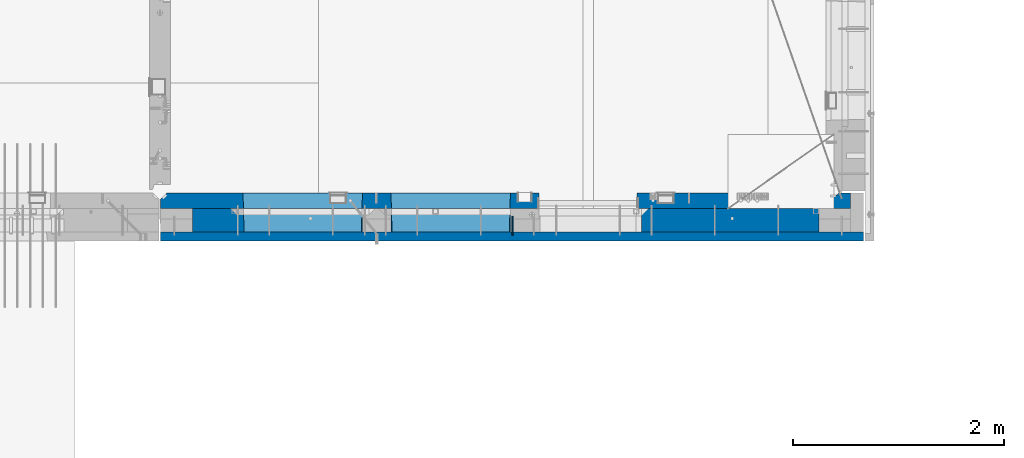
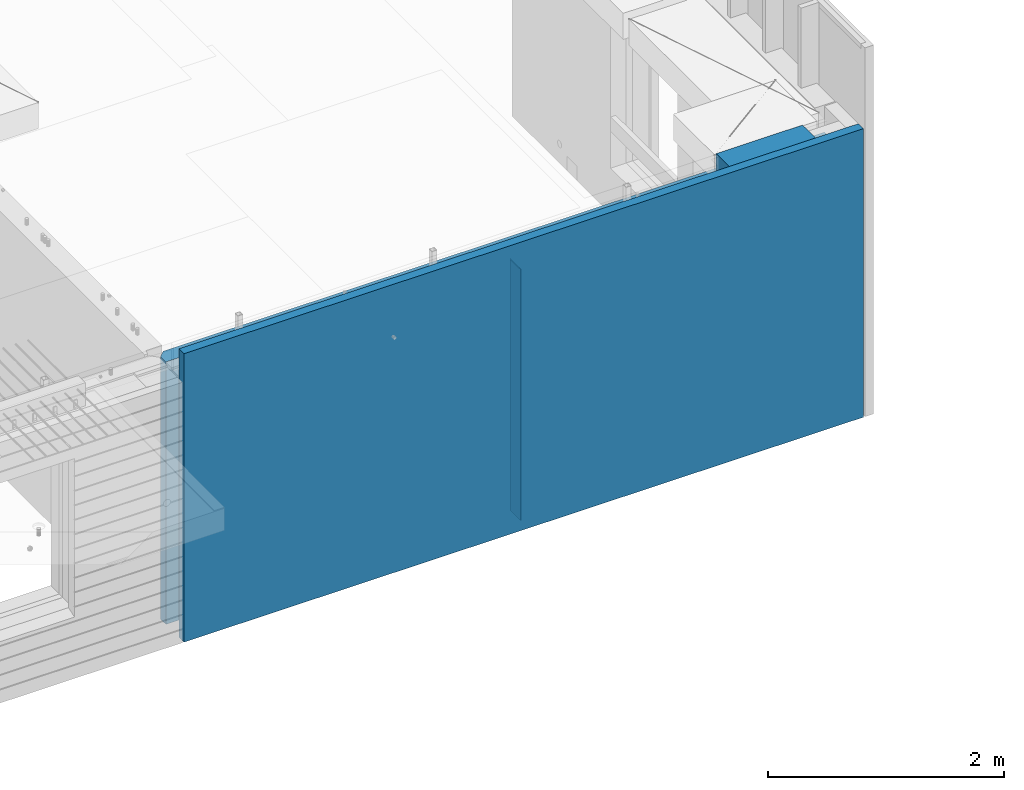
# One storey, part 199 of 309: 4 walls, 1 element without a shape of its own.
"""IFC2X3 building model written with IfcOpenShell, lengths in millimetres."""

from ifc_helpers import new_model, si_unit, frame, origin_with_axes, place, context, subcontext, project, spatial, faceted_brep, material, type_object, element, aggregate, save


model = new_model("IFC2X3")

# Units and contexts
model_context = context("Model", 3, precision=1e-05, world=origin_with_axes())
body_context = subcontext(model_context, "Body", "Model", "MODEL_VIEW")
ifc_project = project(units=[si_unit("LENGTHUNIT", "METRE", prefix="MILLI"), si_unit("AREAUNIT", "SQUARE_METRE"), si_unit("VOLUMEUNIT", "CUBIC_METRE"), si_unit("MASSUNIT", "GRAM", prefix="KILO"), si_unit("TIMEUNIT", "SECOND"), si_unit("PLANEANGLEUNIT", "RADIAN"), si_unit("SOLIDANGLEUNIT", "STERADIAN"), si_unit("THERMODYNAMICTEMPERATUREUNIT", "DEGREE_CELSIUS"), si_unit("LUMINOUSINTENSITYUNIT", "LUMEN")], contexts=[model_context])

# Site, building, storey
site_placement = place(None, origin_with_axes())
site = spatial("IfcSite", under=ifc_project, at=site_placement, CompositionType="ELEMENT")
building_placement = place(site_placement, origin_with_axes())
building = spatial("IfcBuilding", under=site, at=building_placement, CompositionType="ELEMENT")
storey_placement = place(building_placement, origin_with_axes())
storey = spatial("IfcBuildingStorey", under=building, at=storey_placement, Name="7", CompositionType="ELEMENT", Elevation=0.0)

# Assembly, walls
assembly_placement = place(storey_placement, origin_with_axes())
assembly = element("IfcElementAssembly", 1, at=assembly_placement, inside=storey, AssemblyPlace="NOTDEFINED", PredefinedType="REINFORCEMENT_UNIT")
ifc_material_1 = material(Name="Undefined")
wall_type_1 = type_object("IfcWallType", PredefinedType="NOTDEFINED")
wall_1_placement = place(assembly_placement, frame((31944.9998946285, 7780.0, 101115.0), z_axis=(0.0, 0.0, 1.0), x_axis=(0.0, -1.0, 0.0)))
wall_1 = element("IfcWall", 2, at=wall_1_placement, type_object=wall_type_1, material=ifc_material_1, Name="(PD)", context=body_context, shape_type="Brep", body=[
    faceted_brep([(0.0, 5.0, -1300.0), (0.0, 5.0, 1300.0), (180.0, 5.0, 1300.0), (180.0, 5.0, -1300.0), (0.0, -5.0, 1300.0), (180.0, -5.0, 1300.0), (0.0, -5.0, -1300.0), (180.0, -5.0, -1300.0)], [[[0, 1, 2, 3]], [[1, 4, 5, 2]], [[4, 6, 7, 5]], [[6, 0, 3, 7]], [[5, 7, 3, 2]], [[6, 4, 1, 0]]]),
])
ifc_material_2 = material(Name="COS5gt")
wall_type_2 = type_object("IfcWallType", PredefinedType="NOTDEFINED")
wall_2_placement = place(assembly_placement, frame((34845.0, 7740.0, 101247.5), z_axis=(0.0, 0.0, 1.0), x_axis=(-1.0, 3.00000001838171e-08, 0.0)))
wall_2 = element("IfcWall", 3, at=wall_2_placement, type_object=wall_type_2, material=ifc_material_2, context=body_context, shape_type="Brep", body=[
    faceted_brep([(845.0, -110.0, 1492.5), (845.0, -110.0, 1202.5), (845.0, 110.0, 1202.5), (845.0, 110.0, 1492.5), (0.0, 110.0, 1492.5), (0.0, -110.0, 1492.5), (0.0, -110.0, -1492.5), (1680.00110766775, -110.0, -1492.5), (1680.00110766775, -110.0, 857.5), (2649.99996185248, -110.0, 857.5), (2649.99996185248, -110.0, 1202.5), (0.0, 90.0, -1492.5), (1680.00110766775, 90.0, -1492.5), (0.0, 90.0, -1442.5), (1680.00110766775, 90.0, -1442.5), (0.0, 110.0, -1442.5), (1680.00110766775, 110.0, -1442.5), (1680.00110766775, 110.0, 857.5), (2649.99996185248, 110.0, 857.5), (2649.99996185248, -10.0, 857.5), (2649.99996185248, -10.0, 1202.5), (2649.99996185248, 110.0, 1202.5), (4049.99996185248, -10.0, 1202.5), (4049.99996185248, -10.0, -1492.5), (4049.99996185248, 90.0, -1492.5), (4049.99996185248, 90.0, -1442.5), (4049.99996185248, 110.0, -1442.5), (4049.99996185248, 110.0, 1202.5), (2920.0018706072, 110.0, 1202.5), (2920.0018706072, -10.0, 1202.5), (2920.0018706072, -110.0, 1202.5), (4049.99996185248, -110.0, 1202.5), (2920.0018706072, 110.0, -1442.5), (2920.0018706072, 90.0, -1442.5), (2920.0018706072, 90.0, -1492.5), (2920.0018706072, -10.0, -1492.5), (2920.0018706072, -110.0, -1492.5), (4045.94781655315, -110.0, -813.445945945947), (4040.0018706072, 110.0, -807.5), (4010.0018706072, 110.0, -807.5), (2960.0018706072, 110.0, -807.5), (2930.0018706072, 110.0, -807.5), (2924.05592466125, -110.0, -813.445945945947), (4049.99996185248, -110.0, -1492.5), (2924.05592466125, -110.0, 813.445945945947), (4045.94781655315, -110.0, 813.445945945947), (4040.0018706072, 110.0, -802.5), (4040.0018706072, 110.0, 807.5), (2930.0018706072, 110.0, 807.5), (2930.0018706072, 110.0, -802.5), (4320.0018706072, -10.0, 1202.5), (4320.0018706072, 110.0, 1202.5), (4320.0018706072, 110.0, -1442.5), (4320.0018706072, 90.0, -1442.5), (4320.0018706072, 90.0, -1492.5), (4320.0018706072, -10.0, -1492.5), (5928.5, 90.0, -1442.5), (5928.5, 90.0, -1492.5), (5928.5, 110.0, -1442.5), (5928.5, 110.0, -1492.5), (5930.0, -110.0, -1492.5), (5930.0, 110.0, -1492.5), (5930.0, 110.0, 1202.5), (5930.0, -110.0, 1202.5), (4320.0018706072, -110.0, -1492.5), (4320.0018706072, -110.0, 1202.5), (5445.94552773479, -110.0, -813.445945945947), (5439.99958178884, 110.0, -807.5), (5409.99958178884, 110.0, -807.5), (4359.99958178884, 110.0, -807.5), (4329.99958178884, 110.0, -807.5), (4324.05363584289, -110.0, -813.445945945947), (4324.05363584289, -110.0, 813.445945945947), (5445.94552773479, -110.0, 813.445945945947), (5439.99958178884, 110.0, -802.5), (5439.99958178884, 110.0, 807.5), (4329.99958178884, 110.0, 807.5), (4329.99958178884, 110.0, -802.5)], [[[0, 1, 2, 3]], [[4, 5, 0, 3]], [[1, 0, 5, 6, 7, 8, 9, 10]], [[6, 11, 12, 7]], [[11, 13, 14, 12]], [[11, 6, 5, 4, 15, 13]], [[13, 15, 16, 14]], [[7, 12, 14, 16, 17, 8]], [[8, 17, 18, 19, 9]], [[10, 9, 19, 20]], [[2, 1, 10, 20, 21]], [[17, 16, 15, 4, 3, 2, 21, 18]], [[20, 19, 18, 21]], [[22, 23, 24, 25, 26, 27]], [[28, 29, 30, 31, 22, 27]], [[29, 28, 32, 33, 34, 35]], [[30, 29, 35, 36]], [[37, 38, 39, 40, 41, 42]], [[43, 31, 30, 36], [37, 42, 44, 45]], [[46, 38, 37, 45, 47]], [[44, 48, 47, 45]], [[42, 41, 49, 48, 44]], [[32, 28, 27, 26], [41, 40, 39, 38, 46, 47, 48, 49]], [[33, 32, 26, 25]], [[34, 33, 25, 24]], [[34, 24, 23, 43, 36, 35]], [[31, 43, 23, 22]], [[50, 51, 52, 53, 54, 55]], [[56, 57, 54, 53]], [[58, 56, 53, 52]], [[57, 56, 58, 59]], [[60, 61, 62, 63]], [[54, 57, 59, 61, 60, 64, 55]], [[65, 50, 55, 64]], [[66, 67, 68, 69, 70, 71]], [[60, 63, 65, 64], [66, 71, 72, 73]], [[74, 67, 66, 73, 75]], [[72, 76, 75, 73]], [[71, 70, 77, 76, 72]], [[62, 61, 59, 58, 52, 51], [70, 69, 68, 67, 74, 75, 76, 77]], [[65, 63, 62, 51, 50]]]),
])
ifc_material_3 = material(Name="CONCRETE/C30/37")
wall_type_3 = type_object("IfcWallType", PredefinedType="NOTDEFINED")
wall_3_placement = place(assembly_placement, frame((35265.0, 7587.5, 101247.5), z_axis=(0.0, 0.0, 1.0), x_axis=(-1.0, 3.00000001838171e-08, 0.0)))
wall_3 = element("IfcWall", 4, at=wall_3_placement, type_object=wall_type_3, material=ifc_material_3, context=body_context, shape_type="Brep", body=[
    faceted_brep([(0.0, 42.5, -1492.5), (0.0, 42.5, 1492.5), (6650.0, 42.5, 1492.5), (6650.0, 42.5, -1492.5), (0.0, -42.5, 1492.5), (6650.0, -42.5, 1492.5), (0.0, -42.5, -1492.5), (6650.0, -42.5, -1492.5)], [[[0, 1, 2, 3]], [[1, 4, 5, 2]], [[4, 6, 7, 5]], [[6, 0, 3, 7]], [[5, 7, 3, 2]], [[6, 4, 1, 0]]]),
])
ifc_material_4 = material(Name="CONCRETE/C35/45")
wall_type_4 = type_object("IfcWallType", PredefinedType="NOTDEFINED")
wall_4_placement = place(assembly_placement, frame((35145.0, 7925.0, 101112.5), z_axis=(0.0, 0.0, 1.0), x_axis=(-1.0, 3.00000001838171e-08, 0.0)))
wall_4 = element("IfcWall", 5, at=wall_4_placement, type_object=wall_type_4, material=ifc_material_4, context=body_context, shape_type="Brep", body=[
    faceted_brep([(202.000000451517, -54.9999973486238, 1357.5), (202.000000451517, -54.9999973486238, -1357.5), (214.999999722531, -75.0, -1357.5), (214.999999722531, -75.0, 1357.5), (128.000000410604, -54.9999993903875, 1357.5), (128.000000410604, -54.9999993903875, -1357.5), (115.0, -75.0, 1357.5), (115.0, -75.0, -1357.5), (0.0, -75.0, -1357.5), (0.0, -75.0, 1357.5), (0.0, 75.0, 1357.5), (0.0, 75.0, -1357.5), (6470.0, -75.0, 1357.5), (6530.0, -15.0, 1357.5), (6530.0, 75.0, 1357.5), (6530.0, 75.0, -1357.5), (6530.0, -15.0, -1357.5), (6470.0, -75.0, -1357.5), (2950.00110766775, -75.0, -1357.5), (2946.15495382159, 75.0, -1357.5), (2950.00110766775, -75.0, 952.5), (2946.1549538216, 75.0, 948.653846153844), (2020.00110766775, -75.0, 952.5), (2023.8472615139, 75.0, 948.653846153844), (2020.00110766775, -75.0, -1357.5), (2023.8472615139, 75.0, -1357.5), (5749.99958178884, -75.0, -682.5), (5745.94552773479, 75.0, -678.445945945947), (4624.05363584289, 75.0, -678.445945945947), (4619.99958178884, -75.0, -682.5), (5749.99958178884, -75.0, 952.5), (5745.94552773479, 75.0, 948.445945945947), (4619.99958178884, -75.0, 952.5), (4624.05363584289, 75.0, 948.445945945947), (4345.94781655315, 75.0, -678.445945945947), (4345.94781655315, 75.0, 948.445945945947), (3224.05592466125, 75.0, 948.445945945947), (3224.05592466125, 75.0, -678.445945945947), (3220.0018706072, -75.0, -682.5), (3220.0018706072, -75.0, 952.5), (4350.0018706072, -75.0, -682.5), (4350.0018706072, -75.0, 952.5)], [[[0, 1, 2, 3]], [[4, 5, 1, 0]], [[6, 7, 5, 4]], [[8, 9, 10, 11]], [[0, 3, 12, 13, 14, 10, 9, 6, 4]], [[15, 14, 13, 16]], [[12, 17, 16, 13]], [[15, 16, 17, 18, 19]], [[19, 18, 20, 21]], [[22, 23, 21, 20]], [[24, 25, 23, 22]], [[26, 27, 28, 29]], [[27, 26, 30, 31]], [[32, 33, 31, 30]], [[29, 28, 33, 32]], [[11, 10, 14, 15, 19, 21, 23, 25], [34, 35, 36, 37], [27, 31, 33, 28]], [[38, 37, 36, 39]], [[40, 34, 37, 38]], [[34, 40, 41, 35]], [[39, 36, 35, 41]], [[24, 22, 20, 18, 17, 12, 3, 2], [40, 38, 39, 41], [26, 29, 32, 30]], [[8, 11, 25, 24, 2, 1, 5, 7]], [[9, 8, 7, 6]]]),
])
aggregate(assembly, [wall_1, wall_2, wall_3, wall_4])

save(model, "model.ifc")
